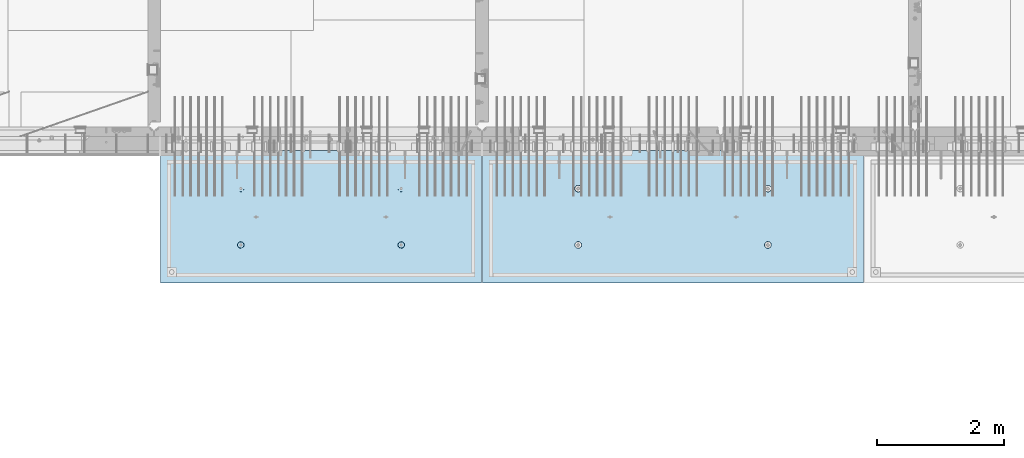
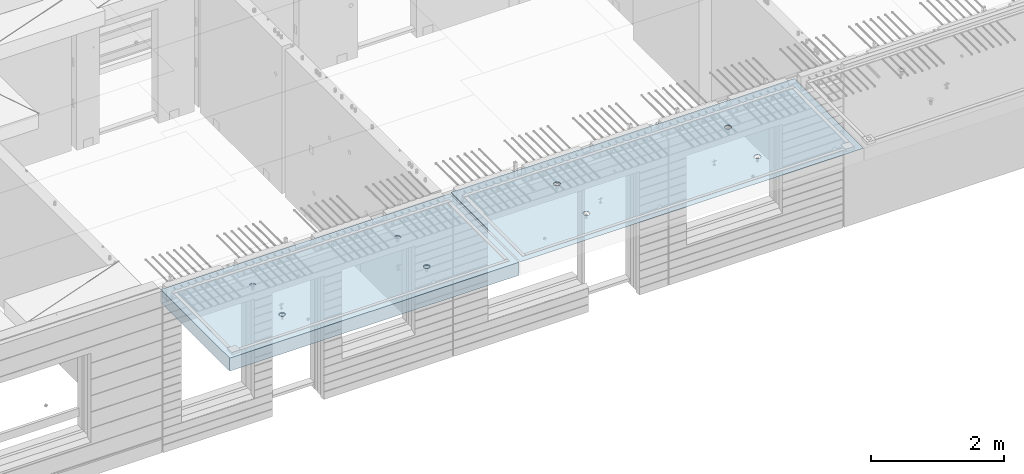
# One storey, part 202 of 350: 2 slabs, 2 elements without a shape of their own.
"""IFC2X3 building model written with IfcOpenShell, lengths in millimetres."""

from ifc_helpers import new_model, si_unit, frame, origin_with_axes, place, context, subcontext, project, spatial, faceted_brep, material, type_object, element, aggregate, save


model = new_model("IFC2X3")

# Units and contexts
model_context = context("Model", 3, precision=1e-05, world=origin_with_axes())
body_context = subcontext(model_context, "Body", "Model", "MODEL_VIEW")
ifc_project = project(units=[si_unit("LENGTHUNIT", "METRE", prefix="MILLI"), si_unit("AREAUNIT", "SQUARE_METRE"), si_unit("VOLUMEUNIT", "CUBIC_METRE"), si_unit("MASSUNIT", "GRAM", prefix="KILO"), si_unit("TIMEUNIT", "SECOND"), si_unit("PLANEANGLEUNIT", "RADIAN"), si_unit("SOLIDANGLEUNIT", "STERADIAN"), si_unit("THERMODYNAMICTEMPERATUREUNIT", "DEGREE_CELSIUS"), si_unit("LUMINOUSINTENSITYUNIT", "LUMEN")], contexts=[model_context])

# Site, building, storey
site_placement = place(None, origin_with_axes())
site = spatial("IfcSite", under=ifc_project, at=site_placement, CompositionType="ELEMENT")
building_placement = place(site_placement, origin_with_axes())
building = spatial("IfcBuilding", under=site, at=building_placement, CompositionType="ELEMENT")
storey_placement = place(building_placement, origin_with_axes())
storey = spatial("IfcBuildingStorey", under=building, at=storey_placement, Name="2", CompositionType="ELEMENT", Elevation=0.0)

# Assembly, slab
assembly_1_placement = place(storey_placement, origin_with_axes())
assembly_1 = element("IfcElementAssembly", 1, at=assembly_1_placement, inside=storey, AssemblyPlace="NOTDEFINED", PredefinedType="REINFORCEMENT_UNIT")
ifc_material = material(Name="CONCRETE/C35/45")
slab_type_1 = type_object("IfcSlabType", PredefinedType="NOTDEFINED")
slab_1_placement = place(assembly_1_placement, frame((27799.9998568133, 7629.99655735226, 87720.0), z_axis=(-1.11800000013248e-06, -0.999999999999375, 0.0), x_axis=(-0.999999999999093, 1.34699999998405e-06, 0.0)))
slab_1 = element("IfcSlab", 2, at=slab_1_placement, type_object=slab_type_1, material=ifc_material, PredefinedType="FLOOR", context=body_context, shape_type="Brep", body=[
    faceted_brep([(4430.38332613536, -4.08995228011918, 616.123557002266), (4431.90609271965, 10.0, 615.628782084005), (4439.08875686405, 10.0, 629.725594302773), (4437.8062304225, -3.95053914321761, 630.657402050439), (4450.27603094506, 10.0, 640.912894136913), (4449.35160622641, -3.83996043598745, 642.185252526786), (4464.3728266293, 10.0, 648.095590732159), (4463.88931892896, -3.76899254079035, 649.583668593681), (4479.99925133704, 10.0, 650.570591700976), (4479.99924953932, -3.74454363348195, 652.132471659324), (4495.6256817422, 10.0, 648.095626704194), (4496.1091860045, -3.76899218543258, 649.583705640341), (4509.72249396096, 10.0, 640.912962559792), (4510.64691570547, -3.83995975981816, 642.185323015524), (4520.9097937951, 10.0, 629.725688478787), (4522.19231800603, -3.95053821212787, 630.657499116635), (4528.09249039035, 10.0, 615.628892794549), (4529.6152557173, -4.08995118488383, 616.123671179757), (4530.56749135917, 10.0, 600.002468086805), (4532.18619485158, -4.24459073322942, 600.002469949934), (4528.09252636238, 10.0, 584.37603768165), (4529.64872932557, -4.39933455047139, 583.870398667863), (4520.90986221798, 10.0, 570.279225462882), (4522.24649000407, -4.53902051890327, 569.308110882728), (4509.72258813697, 10.0, 559.091925628744), (4510.70111430095, -4.6499364652409, 557.745103167879), (4495.62579245274, 10.0, 551.909229033497), (4496.142736776, -4.72117719323433, 550.318244231095), (4479.99936774499, 10.0, 549.43422806468), (4479.99936967367, -4.74573031402542, 547.758576892632), (4464.37293733984, 10.0, 551.909193061462), (4463.8559966665, -4.72117755009094, 550.318207030491), (4450.27612512107, 10.0, 559.091857205865), (4449.29760201216, -4.64993714379671, 557.745032430054), (4439.08882528693, 10.0, 570.279131286869), (4437.75219965053, -4.53902145239408, 569.308013567449), (4431.90612869169, 10.0, 584.375926971106), (4430.34992677396, -4.39933564719104, 583.87028433643), (4429.43112772287, 10.0, 600.002351678851), (4427.81242409951, -4.24459188559558, 600.002349815723), (0.0, 10.0, 0.0), (0.0, -10.0, 0.0), (0.000819232023786753, 10.0, 2085.00366210937), (5980.0, 10.0, -2.4019755073823e-09), (5980.0, -10.0, -2.4019755073823e-09), (5980.0009765625, 10.0, 2085.00366210937), (1450.3499233011, -4.39936856077111, 583.866853138679), (1451.90612877595, 10.0, 584.37249692914), (1449.43112780714, 10.0, 599.998921636884), (1447.81242044485, -4.24462478808709, 599.998919773752), (1457.75219670802, -4.53905437597132, 569.304581326389), (1459.0888253712, 10.0, 570.275701244902), (1469.29759989681, -4.64997007531929, 557.741599360567), (1470.27612520534, 10.0, 559.088427163899), (1483.85599559418, -4.7212104867067, 550.31477342891), (1484.3729374241, 10.0, 551.905763019495), (1499.99936975794, -4.74576325241651, 547.755143107666), (1499.99936782926, 10.0, 549.430798022713), (1516.14273801685, -4.72121012986463, 550.314810629518), (1515.62579253701, 10.0, 551.905798991532), (1530.70111658485, -4.64996939677803, 557.741670098397), (1529.72258822124, 10.0, 559.088495586778), (1542.24649311513, -4.53905344249506, 569.304678641675), (1540.90986230225, 10.0, 570.275795420916), (1549.64873296696, -4.39936746405147, 583.866967470121), (1548.09252644665, 10.0, 584.372607639683), (1552.18619867476, -4.24462363570638, 599.999039907971), (1550.56749144343, 10.0, 599.999038044839), (1549.61525935629, -4.08998407628678, 616.120242292795), (1548.09249047462, 10.0, 615.625462752582), (1542.19232111321, -3.95057109353365, 630.654071270945), (1540.90979387937, 10.0, 629.72225843682), (1530.64691798548, -3.83999263332225, 642.181895995745), (1529.72249404523, 10.0, 640.909532517825), (1516.10918724295, -3.76902505384351, 649.580279150618), (1515.62568182647, 10.0, 648.092196662228), (1499.99924962358, -3.7445765001321, 652.129045352205), (1499.9992514213, 10.0, 650.56716165901), (1483.88931785903, -3.76902540921583, 649.580242103954), (1484.37282671356, 10.0, 648.092160690191), (1469.35160411493, -3.83999330949155, 642.181825507), (1470.27603102933, 10.0, 640.909464094946), (1457.80622748385, -3.9505720246525, 630.653974204743), (1459.08875694832, 10.0, 629.722164260806), (1450.3833226649, -4.08998517153668, 616.120128115297), (1451.90609280392, 10.0, 615.625352042039), (1450.18528173966, 4.08930273250735, 1468.81238974452), (1450.82407776805, 10.0, 1469.01994796889), (1448.29345879993, 10.0, 1484.99752828805), (1447.63943102495, 4.24455558012414, 1484.99752753526), (1457.61190709188, 3.94915737991687, 1454.20221107617), (1458.16818327555, 10.0, 1454.60637035917), (1469.19529226424, 3.83787679090165, 1442.60118929624), (1469.60688310596, 10.0, 1443.16769686061), (1483.80158206606, 3.76640201332339, 1435.14993064656), (1484.02047762178, 10.0, 1435.82362453319), (1499.99806458492, 3.74176847410854, 1432.58187967207), (1499.99806376637, 10.0, 1433.29304234547), (1516.19454117951, 3.76640237134416, 1435.14996796955), (1515.97564408552, 10.0, 1435.82366131359), (1530.80081379559, 3.8378774716839, 1442.60126026678), (1530.38922169525, 10.0, 1443.16776682109), (1542.38417222175, 3.94915831647813, 1454.2023087116), (1541.82789519381, 10.0, 1454.6064666515), (1549.8107639085, 4.08930383282132, 1468.81250445209), (1549.17196752123, 10.0, 1469.02006116732), (1552.35657735256, 4.24455673628836, 1484.9976480647), (1551.70254970896, 10.0, 1484.99764731191), (1549.77718017658, 4.39970502781216, 1501.17188586406), (1549.17193074083, 10.0, 1500.97522763107), (1542.32982200517, 4.53957665037888, 1515.75352812725), (1541.82782523334, 10.0, 1515.38880524079), (1530.74643689407, 4.65051889081951, 1527.31927700612), (1530.38912540293, 10.0, 1526.82747873935), (1516.16088003051, 4.72171993891243, 1534.74199930817), (1515.9755308871, 10.0, 1534.17155106677), (1499.99794405534, 4.74624892331485, 1537.2991504223), (1499.99794474251, 10.0, 1536.70213325449), (1483.83501395426, 4.72171958237595, 1534.74196213963), (1484.02036442336, 10.0, 1534.17151428637), (1469.24947414505, 4.65051821242378, 1527.31920628548), (1469.60678681363, 10.0, 1526.82740877888), (1457.66611561777, 4.53957571620413, 1515.75343074172), (1458.16811331507, 10.0, 1515.38870894846), (1450.21879098044, 4.39970392896794, 1501.17177131094), (1450.82404098765, 10.0, 1500.97511443265), (4495.97553080284, 10.0, 1534.17498110874), (4496.16087879206, 4.72175280732336, 1534.74542579789), (4479.99794397108, 4.746281789965, 1537.30257672942), (4479.99794465824, 10.0, 1536.70556329646), (4510.38912531866, 10.0, 1526.83090878132), (4510.74643461406, 4.65055176430906, 1527.3227040259), (4521.82782514907, 10.0, 1515.39223528276), (4522.32981889799, 4.53960953179921, 1515.75695597294), (4529.17193065656, 10.0, 1500.97865767303), (4529.77717653759, 4.39973791921511, 1501.17531475103), (4531.70254962468, 10.0, 1485.00107735388), (4532.35657352936, 4.24458963877987, 1485.00107810666), (4529.17196743696, 10.0, 1469.02349120928), (4529.8107602671, 4.08933674640139, 1468.81593564983), (4521.82789510954, 10.0, 1454.60989669347), (4522.38416911069, 3.94919124005537, 1454.20574095265), (4510.38922161098, 10.0, 1443.17119686305), (4510.8008115117, 3.83791040322103, 1442.60469333626), (4495.97564400126, 10.0, 1435.82709135556), (4496.19453993865, 3.76643530797446, 1435.15340157113), (4479.99806368211, 10.0, 1433.29647238744), (4479.99806450065, 3.74180141248507, 1432.58531345704), (4464.02047753751, 10.0, 1435.82705457516), (4463.80158313838, 3.76643494995369, 1435.15336424814), (4449.60688302169, 10.0, 1443.17112690258), (4449.19529437959, 3.83790972242423, 1442.60462236572), (4438.16818319128, 10.0, 1454.60980040114), (4437.61191003439, 3.94919030349411, 1454.20564331723), (4430.82407768378, 10.0, 1469.02337801086), (4430.18528521251, 4.08933564607287, 1468.81582094227), (4437.66611855642, 4.53960859763902, 1515.75685858742), (4449.24947625653, 4.65055108592787, 1527.32263330526), (4463.83501502419, 4.72175245078688, 1534.74538862936), (4427.63943467959, 4.24458848261565, 1485.00095757723), (4430.2187944509, 4.39973682038544, 1501.17520019791), (4464.02036433909, 10.0, 1534.17494432834), (4449.60678672936, 10.0, 1526.83083882084), (4438.1681132308, 10.0, 1515.39213899043), (4430.82404090338, 10.0, 1500.97854447461), (4428.29345871566, 10.0, 1485.00095833002)], [[[0, 1, 2, 3]], [[3, 2, 4, 5]], [[5, 4, 6, 7]], [[7, 6, 8, 9]], [[10, 11, 9, 8]], [[12, 13, 11, 10]], [[14, 15, 13, 12]], [[16, 17, 15, 14]], [[18, 19, 17, 16]], [[20, 21, 19, 18]], [[22, 23, 21, 20]], [[24, 25, 23, 22]], [[26, 27, 25, 24]], [[27, 26, 28, 29]], [[29, 28, 30, 31]], [[31, 30, 32, 33]], [[33, 32, 34, 35]], [[35, 34, 36, 37]], [[37, 36, 38, 39]], [[39, 38, 1, 0]], [[40, 41, 42]], [[40, 43, 44, 41]], [[43, 45, 44]], [[46, 47, 48, 49]], [[50, 51, 47, 46]], [[52, 53, 51, 50]], [[54, 55, 53, 52]], [[56, 57, 55, 54]], [[58, 59, 57, 56]], [[59, 58, 60, 61]], [[61, 60, 62, 63]], [[63, 62, 64, 65]], [[65, 64, 66, 67]], [[67, 66, 68, 69]], [[69, 68, 70, 71]], [[71, 70, 72, 73]], [[73, 72, 74, 75]], [[75, 74, 76, 77]], [[78, 79, 77, 76]], [[80, 81, 79, 78]], [[82, 83, 81, 80]], [[84, 85, 83, 82]], [[49, 48, 85, 84]], [[86, 87, 88, 89]], [[90, 91, 87, 86]], [[92, 93, 91, 90]], [[94, 95, 93, 92]], [[96, 97, 95, 94]], [[98, 99, 97, 96]], [[100, 101, 99, 98]], [[101, 100, 102, 103]], [[103, 102, 104, 105]], [[105, 104, 106, 107]], [[107, 106, 108, 109]], [[109, 108, 110, 111]], [[111, 110, 112, 113]], [[113, 112, 114, 115]], [[115, 114, 116, 117]], [[117, 116, 118, 119]], [[120, 121, 119, 118]], [[122, 123, 121, 120]], [[124, 125, 123, 122]], [[89, 88, 125, 124]], [[126, 127, 128, 129]], [[130, 131, 127, 126]], [[132, 133, 131, 130]], [[134, 135, 133, 132]], [[136, 137, 135, 134]], [[138, 139, 137, 136]], [[140, 141, 139, 138]], [[142, 143, 141, 140]], [[143, 142, 144, 145]], [[145, 144, 146, 147]], [[147, 146, 148, 149]], [[149, 148, 150, 151]], [[151, 150, 152, 153]], [[153, 152, 154, 155]], [[41, 44, 45, 42], [3, 5, 7, 9, 11, 13, 15, 17, 19, 21, 23, 25, 27, 29, 31, 33, 35, 37, 39, 0], [156, 157, 158, 128, 127, 131, 133, 135, 137, 139, 141, 143, 145, 147, 149, 151, 153, 155, 159, 160], [122, 120, 118, 116, 114, 112, 110, 108, 106, 104, 102, 100, 98, 96, 94, 92, 90, 86, 89, 124], [82, 80, 78, 76, 74, 72, 70, 68, 66, 64, 62, 60, 58, 56, 54, 52, 50, 46, 49, 84]], [[129, 128, 158, 161]], [[157, 162, 161, 158]], [[156, 163, 162, 157]], [[160, 164, 163, 156]], [[159, 165, 164, 160]], [[155, 154, 165, 159]], [[43, 40, 42, 45], [34, 32, 30, 28, 26, 24, 22, 20, 18, 16, 14, 12, 10, 8, 6, 4, 2, 1, 38, 36], [152, 150, 148, 146, 144, 142, 140, 138, 136, 134, 132, 130, 126, 129, 161, 162, 163, 164, 165, 154], [91, 93, 95, 97, 99, 101, 103, 105, 107, 109, 111, 113, 115, 117, 119, 121, 123, 125, 88, 87], [51, 53, 55, 57, 59, 61, 63, 65, 67, 69, 71, 73, 75, 77, 79, 81, 83, 85, 48, 47]]]),
])
aggregate(assembly_1, [slab_1])

assembly_2_placement = place(storey_placement, origin_with_axes())
assembly_2 = element("IfcElementAssembly", 3, at=assembly_2_placement, inside=storey, AssemblyPlace="NOTDEFINED", PredefinedType="REINFORCEMENT_UNIT")
slab_type_2 = type_object("IfcSlabType", PredefinedType="NOTDEFINED")
slab_2_placement = place(assembly_2_placement, frame((21799.9998568133, 7629.99655735226, 87590.0), z_axis=(-1.11800000013248e-06, -0.999999999999375, 0.0), x_axis=(-0.999999999999093, 1.34699999998405e-06, 0.0)))
slab_2 = element("IfcSlab", 4, at=slab_2_placement, type_object=slab_type_2, material=ifc_material, PredefinedType="FLOOR", context=body_context, shape_type="Brep", body=[
    faceted_brep([(1275.44980856604, -115.0, 552.444777751491), (1289.3882117606, -115.0, 559.546772887367), (1300.44978375459, -115.0, 570.608375101608), (1307.55174081072, -115.0, 584.54679769877), (1309.9988938901, -115.0, 599.997650760343), (1307.551698599, -115.0, 615.448497136235), (1300.44970346313, -115.0, 629.3869003308), (1289.38810124889, -115.0, 640.448472324786), (1275.44967865172, -115.0, 647.550429380917), (1259.99882559015, -115.0, 649.997582460297), (1244.54797921425, -115.0, 647.550387169195), (1230.60957601969, -115.0, 640.44839203332), (1219.54800402571, -115.0, 629.386789819078), (1212.44604696957, -115.0, 615.448367221916), (1209.9988938902, -115.0, 599.997514160343), (1212.4460891813, -115.0, 584.546667784451), (1219.54808431717, -115.0, 570.608264589886), (1230.60968653141, -115.0, 559.546692595902), (1244.54810912857, -115.0, 552.444735539769), (1259.99896219015, -115.0, 549.99758246039), (1219.08841602657, -120.0, 570.274295068632), (1211.90571640051, -120.0, 584.371089208588), (1230.27571826597, -120.0, 559.087023392896), (1244.37253202901, -120.0, 551.904362279308), (1259.99896296629, -120.0, 549.429400642209), (1275.6253871419, -120.0, 551.904404970708), (1289.72218128186, -120.0, 559.087104596764), (1300.9094529576, -120.0, 570.274406836168), (1308.09211407118, -120.0, 584.371220599207), (1310.56707570828, -120.0, 599.99765153648), (1308.09207137979, -120.0, 615.624075712098), (1300.90937175373, -120.0, 629.720869852056), (1289.72206951433, -120.0, 640.90814152779), (1275.62525575129, -120.0, 648.090802641378), (1259.99882481401, -120.0, 650.565764278478), (1244.37240063839, -120.0, 648.090759949978), (1230.27560649844, -120.0, 640.908060323922), (1219.0883348227, -120.0, 629.72075808452), (1211.90567370912, -120.0, 615.623944321479), (1209.43071207202, -120.0, 599.997513384206), (0.000328360383718973, -120.0, 2085.00366210938), (5040.00048828125, -120.0, 2085.00366210938), (5040.00048828125, 120.0, 2085.00366210938), (0.000328360383718973, 120.0, 2085.00366210938), (5040.0, -120.0, -2.18278728425503e-09), (5040.0, 120.0, -2.18278728425503e-09), (-7.27595761418343e-12, -120.0, -9.09494701772928e-13), (-7.27595761418343e-12, 120.0, -9.09494701772928e-13), (1275.44859965604, -105.0, 1437.44477775066), (1289.38700285061, -105.0, 1444.54677288654), (1300.44857484459, -105.0, 1455.60837510078), (1307.55053190072, -105.0, 1469.54679769794), (1309.9976849801, -105.0, 1484.99765075952), (1307.550489689, -105.0, 1500.44849713541), (1300.44849455313, -105.0, 1514.38690032997), (1289.38689233888, -105.0, 1525.44847232396), (1275.44846974172, -105.0, 1532.55042938009), (1259.99761668015, -105.0, 1534.99758245947), (1244.54677030425, -105.0, 1532.55038716837), (1230.60836710969, -105.0, 1525.44839203249), (1219.5467951157, -105.0, 1514.38678981825), (1212.44483805958, -105.0, 1500.44836722109), (1209.99768498019, -105.0, 1484.99751415952), (1212.44488027129, -105.0, 1469.54666778362), (1219.54687540717, -105.0, 1455.60826458906), (1230.60847762142, -105.0, 1444.54669259508), (1244.54690021857, -105.0, 1437.44473553894), (1259.99775328015, -105.0, 1434.99758245956), (1210.82376192895, -120.0, 1469.01993205604), (1208.29313952565, -120.0, 1484.99751183111), (1218.16787053537, -120.0, 1454.60635602529), (1229.60657282509, -120.0, 1443.16768498606), (1244.02016891989, -120.0, 1435.82361575756), (1259.99775560856, -120.0, 1433.29303700502), (1275.97533538363, -120.0, 1435.82365940832), (1290.38891141437, -120.0, 1443.16776801474), (1301.82758245361, -120.0, 1454.60647030446), (1309.17165168211, -120.0, 1469.02006639925), (1311.70223043464, -120.0, 1484.99765308793), (1309.17160803135, -120.0, 1500.975232863), (1301.82749942493, -120.0, 1515.38880889374), (1290.3887971352, -120.0, 1526.82747993297), (1275.97520104041, -120.0, 1534.17154916147), (1259.99761435174, -120.0, 1536.70212791401), (1244.02003457667, -120.0, 1534.17150551072), (1229.60645854592, -120.0, 1526.8273969043), (1218.16778750669, -120.0, 1515.38869461457), (1210.82371827819, -120.0, 1500.97509851978), (3795.4485995714, -105.0, 1437.44822013263), (3809.38700276596, -105.0, 1444.55021526851), (3820.44857475995, -105.0, 1455.61181748275), (3827.55053181608, -105.0, 1469.55024007991), (3829.99768489545, -105.0, 1485.00109314148), (3827.55048960436, -105.0, 1500.45193951738), (3820.44849446848, -105.0, 1514.39034271194), (3809.38689225424, -105.0, 1525.45191470593), (3795.44846965708, -105.0, 1532.55387176206), (3779.9976165955, -105.0, 1535.00102484144), (3764.54677021961, -105.0, 1532.55382955034), (3750.60836702505, -105.0, 1525.45183441446), (3739.54679503106, -105.0, 1514.39023220022), (3732.44483797493, -105.0, 1500.45180960306), (3729.99768489555, -105.0, 1485.00095654148), (3732.44488018665, -105.0, 1469.55011016559), (3739.54687532252, -105.0, 1455.61170697103), (3750.60847753677, -105.0, 1444.55013497704), (3764.54690013393, -105.0, 1437.44817792091), (3779.9977531955, -105.0, 1435.00102484153), (3730.82376184431, -120.0, 1469.023374438), (3728.293139441, -120.0, 1485.00095421308), (3738.16787045072, -120.0, 1454.60979840726), (3749.60657274045, -120.0, 1443.17112736803), (3764.02016883524, -120.0, 1435.82705813953), (3779.99775552391, -120.0, 1433.29647938699), (3795.97533529898, -120.0, 1435.82710179029), (3810.38891132972, -120.0, 1443.1712103967), (3821.82758236896, -120.0, 1454.60991268643), (3829.17165159746, -120.0, 1469.02350878122), (3831.70223035, -120.0, 1485.00109546989), (3829.1716079467, -120.0, 1500.97867524497), (3821.82749934028, -120.0, 1515.39225127571), (3810.38879705056, -120.0, 1526.83092231494), (3795.97520095576, -120.0, 1534.17499154344), (3779.99761426709, -120.0, 1536.70557029598), (3764.02003449202, -120.0, 1534.17494789268), (3749.60645846128, -120.0, 1526.83083928627), (3738.16778742204, -120.0, 1515.39213699654), (3730.82371819355, -120.0, 1500.97854090175), (3795.4498084814, -115.0, 552.448220133458), (3809.38821167596, -115.0, 559.550215269334), (3820.44978366995, -115.0, 570.611817483575), (3827.55174072608, -115.0, 584.550240080738), (3829.99889380546, -115.0, 600.00109314231), (3827.55169851435, -115.0, 615.451939518203), (3820.44970337848, -115.0, 629.390342712767), (3809.38810116424, -115.0, 640.451914706753), (3795.44967856708, -115.0, 647.553871762884), (3779.9988255055, -115.0, 650.001024842264), (3764.54797912961, -115.0, 647.553829551163), (3750.60957593505, -115.0, 640.451834415288), (3739.54800394106, -115.0, 629.390232201046), (3732.44604688493, -115.0, 615.451809603883), (3729.99889380555, -115.0, 600.000956542311), (3732.44608909665, -115.0, 584.550110166418), (3739.54808423252, -115.0, 570.611706971854), (3750.60968644677, -115.0, 559.550134977869), (3764.54810904393, -115.0, 552.448177921737), (3779.9989621055, -115.0, 550.001024842357), (3731.90571631587, -120.0, 584.374531590555), (3729.43071198737, -120.0, 600.000955766174), (3739.08841594193, -120.0, 570.277737450599), (3750.27571818133, -120.0, 559.090465774863), (3764.37253194437, -120.0, 551.907804661275), (3779.99896288164, -120.0, 549.432843024176), (3795.62538705726, -120.0, 551.907847352675), (3809.72218119721, -120.0, 559.090546978732), (3820.90945287295, -120.0, 570.277849218135), (3828.09211398654, -120.0, 584.374662981175), (3830.56707562364, -120.0, 600.001093918447), (3828.09207129514, -120.0, 615.627518094066), (3820.90937166908, -120.0, 629.724312234023), (3809.72206942968, -120.0, 640.911583909758), (3795.62525566664, -120.0, 648.094245023345), (3779.99882472937, -120.0, 650.569206660445), (3764.37240055375, -120.0, 648.094202331945), (3750.27560641379, -120.0, 640.911502705889), (3739.08833473806, -120.0, 629.724200466487), (3731.90567362447, -120.0, 615.627386703446)], [[[0, 1, 2, 3, 4, 5, 6, 7, 8, 9, 10, 11, 12, 13, 14, 15, 16, 17, 18, 19]], [[20, 16, 15, 21]], [[22, 17, 16, 20]], [[23, 18, 17, 22]], [[24, 19, 18, 23]], [[25, 0, 19, 24]], [[26, 1, 0, 25]], [[27, 2, 1, 26]], [[28, 3, 2, 27]], [[29, 4, 3, 28]], [[30, 5, 4, 29]], [[31, 6, 5, 30]], [[32, 7, 6, 31]], [[33, 8, 7, 32]], [[34, 9, 8, 33]], [[35, 10, 9, 34]], [[36, 11, 10, 35]], [[37, 12, 11, 36]], [[38, 13, 12, 37]], [[39, 14, 13, 38]], [[21, 15, 14, 39]], [[40, 41, 42, 43]], [[41, 44, 45, 42]], [[44, 46, 47, 45]], [[42, 45, 47, 43]], [[46, 40, 43, 47]], [[48, 49, 50, 51, 52, 53, 54, 55, 56, 57, 58, 59, 60, 61, 62, 63, 64, 65, 66, 67]], [[68, 63, 62, 69]], [[70, 64, 63, 68]], [[71, 65, 64, 70]], [[72, 66, 65, 71]], [[73, 67, 66, 72]], [[74, 48, 67, 73]], [[75, 49, 48, 74]], [[76, 50, 49, 75]], [[77, 51, 50, 76]], [[78, 52, 51, 77]], [[79, 53, 52, 78]], [[80, 54, 53, 79]], [[81, 55, 54, 80]], [[82, 56, 55, 81]], [[83, 57, 56, 82]], [[84, 58, 57, 83]], [[85, 59, 58, 84]], [[86, 60, 59, 85]], [[87, 61, 60, 86]], [[69, 62, 61, 87]], [[88, 89, 90, 91, 92, 93, 94, 95, 96, 97, 98, 99, 100, 101, 102, 103, 104, 105, 106, 107]], [[108, 103, 102, 109]], [[110, 104, 103, 108]], [[111, 105, 104, 110]], [[112, 106, 105, 111]], [[113, 107, 106, 112]], [[114, 88, 107, 113]], [[115, 89, 88, 114]], [[116, 90, 89, 115]], [[117, 91, 90, 116]], [[118, 92, 91, 117]], [[119, 93, 92, 118]], [[120, 94, 93, 119]], [[121, 95, 94, 120]], [[122, 96, 95, 121]], [[123, 97, 96, 122]], [[124, 98, 97, 123]], [[125, 99, 98, 124]], [[126, 100, 99, 125]], [[127, 101, 100, 126]], [[109, 102, 101, 127]], [[128, 129, 130, 131, 132, 133, 134, 135, 136, 137, 138, 139, 140, 141, 142, 143, 144, 145, 146, 147]], [[148, 143, 142, 149]], [[150, 144, 143, 148]], [[151, 145, 144, 150]], [[152, 146, 145, 151]], [[153, 147, 146, 152]], [[154, 128, 147, 153]], [[155, 129, 128, 154]], [[156, 130, 129, 155]], [[157, 131, 130, 156]], [[158, 132, 131, 157]], [[159, 133, 132, 158]], [[160, 134, 133, 159]], [[161, 135, 134, 160]], [[162, 136, 135, 161]], [[163, 137, 136, 162]], [[164, 138, 137, 163]], [[165, 139, 138, 164]], [[166, 140, 139, 165]], [[167, 141, 140, 166]], [[149, 142, 141, 167]], [[44, 41, 40, 46], [37, 36, 35, 34, 33, 32, 31, 30, 29, 28, 27, 26, 25, 24, 23, 22, 20, 21, 39, 38], [166, 165, 164, 163, 162, 161, 160, 159, 158, 157, 156, 155, 154, 153, 152, 151, 150, 148, 149, 167], [126, 125, 124, 123, 122, 121, 120, 119, 118, 117, 116, 115, 114, 113, 112, 111, 110, 108, 109, 127], [86, 85, 84, 83, 82, 81, 80, 79, 78, 77, 76, 75, 74, 73, 72, 71, 70, 68, 69, 87]]]),
])
aggregate(assembly_2, [slab_2])

save(model, "model.ifc")
